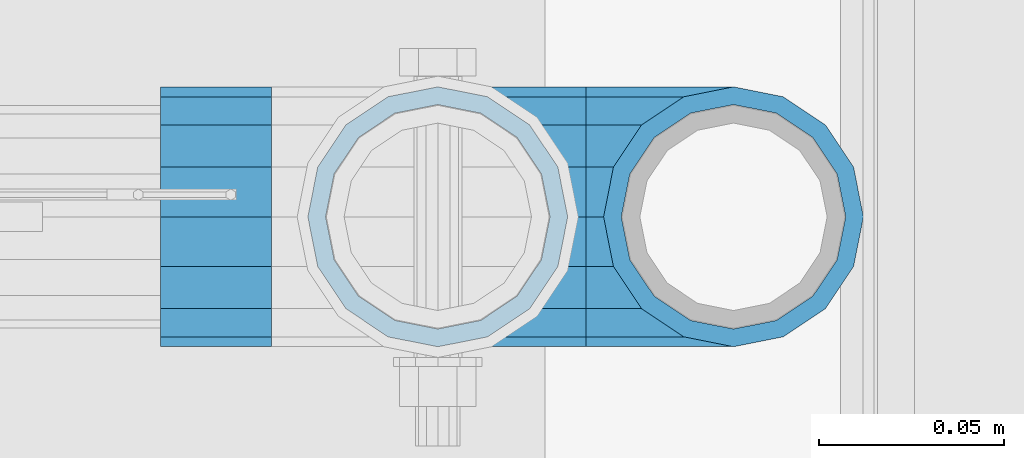
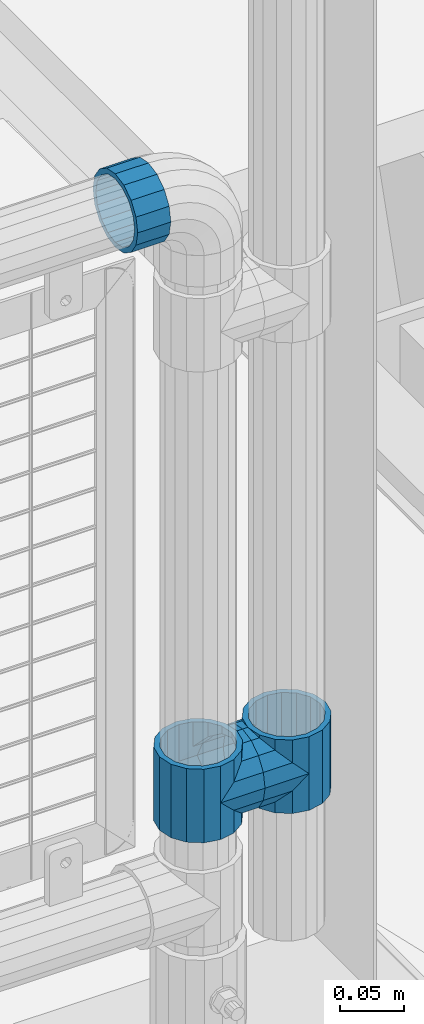
# One storey, part 130 of 193: 5 beams.
"""IFC2X3 building model written with IfcOpenShell, lengths in millimetres."""

from ifc_helpers import new_model, si_unit, frame, origin_with_axes, place, context, subcontext, project, spatial, faceted_brep, material, type_object, element, save


model = new_model("IFC2X3")

# Units and contexts
model_context = context("Model", 3, precision=1e-05, world=origin_with_axes())
body_context = subcontext(model_context, "Body", "Model", "MODEL_VIEW")
ifc_project = project(units=[si_unit("LENGTHUNIT", "METRE", prefix="MILLI"), si_unit("AREAUNIT", "SQUARE_METRE"), si_unit("VOLUMEUNIT", "CUBIC_METRE"), si_unit("MASSUNIT", "GRAM", prefix="KILO"), si_unit("TIMEUNIT", "SECOND"), si_unit("PLANEANGLEUNIT", "RADIAN"), si_unit("SOLIDANGLEUNIT", "STERADIAN"), si_unit("THERMODYNAMICTEMPERATUREUNIT", "DEGREE_CELSIUS"), si_unit("LUMINOUSINTENSITYUNIT", "LUMEN")], contexts=[model_context])

# Site, building, storey
site_placement = place(None, origin_with_axes())
site = spatial("IfcSite", under=ifc_project, at=site_placement, CompositionType="ELEMENT")
building_placement = place(site_placement, origin_with_axes())
building = spatial("IfcBuilding", under=site, at=building_placement, Name="Standard", CompositionType="ELEMENT")
storey_placement = place(building_placement, origin_with_axes())
storey = spatial("IfcBuildingStorey", under=building, at=storey_placement, Name="Undefined", CompositionType="ELEMENT", Elevation=0.0)

# Beams
ifc_material = material(Name="Misc_Undefined")
beam_type = type_object("IfcBeamType", PredefinedType="NOTDEFINED")
beam_1_placement = place(storey_placement, frame((-29019.0, 28664.5, 398.670000000003), z_axis=(0.0, -1.0, 0.0), x_axis=(1.0, 0.0, 0.0)))
element("IfcBeam", 1, at=beam_1_placement, inside=storey, type_object=beam_type, material=ifc_material, context=body_context, shape_type="Brep", body=[
    faceted_brep([(0.0, 0.0, -35.1500000000015), (13.4513226476338, -13.4513226476329, -32.4743655677703), (13.4513226476338, 13.4513226476329, -32.4743655677703), (32.4743655677703, 32.4743655677717, 13.4513226476338), (32.4743655677703, 26.8123795176754, 13.4513226476338), (27.1226768591041, 21.4606908090117, 21.46069080901), (24.8548033587067, 16.3810424080078, 24.8548033587067), (24.8548033587067, 24.8548033587072, 24.8548033587067), (0.0, 0.0, 35.1500000000015), (13.4513226476338, 13.4513226476329, 32.4743655677703), (13.4513226476338, -13.4513226476329, 32.4743655677703), (20.0882031229849, 11.6144421722805, 28.0397438117179), (16.6306603983685, 0.0, 30.3499999999985), (20.0882031229849, -11.6144421722805, 28.0397438117179), (24.8548033587067, -16.3810424080013, 24.8548033587067), (24.8548033587067, -24.8548033587072, 24.8548033587067), (27.1226768591041, -21.4606908090117, 21.46069080901), (32.4743655677703, -26.8123795176776, 13.4513226476338), (32.4743655677703, -32.4743655677717, 13.4513226476338), (32.8397438117208, -28.0397438117175, 11.614442172282), (35.1500000000015, -30.35, 0.0), (35.1500000000015, -35.15, 0.0), (32.4743655677703, -26.8123795176754, -13.4513226476338), (32.4743655677703, -32.4743655677717, -13.4513226476338), (32.8397438117172, -28.0397438117175, -11.614442172282), (24.8548033587067, -16.3810424080013, -24.8548033587067), (24.8548033587067, -24.8548033587072, -24.8548033587067), (27.1226768591114, -21.4606908090117, -21.46069080901), (20.0882031229849, -11.6144421722805, -28.0397438117179), (16.6306603983721, 0.0, -30.3499999999985), (20.0882031229849, 11.6144421722805, -28.0397438117179), (24.8548033587067, 16.3810424080013, -24.8548033587067), (24.8548033587067, 24.8548033587072, -24.8548033587067), (27.1226768591114, 21.4606908090117, -21.46069080901), (32.4743655677703, 26.8123795176776, -13.4513226476338), (32.4743655677703, 32.4743655677717, -13.4513226476338), (32.8397438117172, 28.0397438117175, -11.614442172282), (35.1500000000015, 30.35, 0.0), (35.1500000000015, 35.15, 0.0), (32.8397438117208, 28.0397438117175, 11.614442172282), (40.1500000000015, -35.15, 0.0), (40.1500000000015, -32.4743655677718, 13.4513226476338), (40.1500000000015, -24.8548033587072, 24.8548033587067), (40.1500000000015, -13.4513226476329, 32.4743655677703), (40.1500000000015, 0.0, 35.1500000000015), (40.1500000000015, 13.4513226476329, 32.4743655677703), (40.1500000000015, 24.8548033587072, 24.8548033587067), (40.1500000000015, 32.4743655677718, 13.4513226476338), (40.1500000000015, 35.15, 0.0), (40.1500000000015, -24.8548033587072, -24.8548033587067), (40.1500000000015, -32.4743655677718, -13.4513226476338), (40.1500000000015, -13.4513226476329, -32.4743655677703), (40.1500000000015, 0.0, -35.1500000000015), (40.1500000000015, 13.4513226476329, -32.4743655677703), (40.1500000000015, 24.8548033587072, -24.8548033587067), (40.1500000000015, 32.4743655677718, -13.4513226476338), (40.1500000000015, -21.4606908090117, 21.46069080901), (40.1500000000015, -11.6144421722805, 28.0397438117179), (40.1500000000015, 0.0, 30.3499999999985), (40.1500000000015, 11.6144421722805, 28.0397438117179), (40.1500000000015, 21.4606908090117, 21.46069080901), (40.1500000000015, 28.0397438117176, 11.614442172282), (40.1500000000015, 30.35, 0.0), (40.1500000000015, 28.0397438117176, -11.614442172282), (40.1500000000015, 21.4606908090117, -21.46069080901), (40.1500000000015, 11.6144421722805, -28.0397438117179), (40.1500000000015, 0.0, -30.3499999999985), (40.1500000000015, -11.6144421722805, -28.0397438117179), (40.1500000000015, -21.4606908090117, -21.46069080901), (40.1500000000015, -28.0397438117176, -11.614442172282), (40.1500000000015, -30.35, 0.0), (40.1500000000015, -28.0397438117176, 11.614442172282)], [[[0, 1, 2]], [[3, 4, 5, 6, 7]], [[8, 9, 10]], [[7, 6, 11, 12, 13, 14, 15, 10, 9]], [[16, 17, 18, 15, 14]], [[19, 20, 21, 18, 17]], [[22, 23, 21, 20, 24]], [[25, 26, 23, 22, 27]], [[2, 1, 26, 25, 28, 29, 30, 31, 32]], [[32, 31, 33, 34, 35]], [[35, 34, 36, 37, 38]], [[38, 37, 39, 4, 3]], [[40, 41, 18, 21]], [[41, 42, 15, 18]], [[42, 43, 10, 15]], [[43, 44, 8, 10]], [[44, 45, 9, 8]], [[45, 46, 7, 9]], [[46, 47, 3, 7]], [[47, 48, 38, 3]], [[49, 50, 23, 26]], [[51, 49, 26, 1]], [[52, 51, 1, 0]], [[53, 52, 0, 2]], [[54, 53, 2, 32]], [[55, 54, 32, 35]], [[48, 55, 35, 38]], [[50, 40, 21, 23]], [[49, 51, 52, 53, 54, 55, 48, 47, 46, 45, 44, 43, 42, 41, 40, 50], [56, 57, 58, 59, 60, 61, 62, 63, 64, 65, 66, 67, 68, 69, 70, 71]], [[63, 62, 37, 36]], [[33, 64, 63, 36, 34]], [[30, 65, 64, 33, 31]], [[66, 65, 30, 29]], [[67, 66, 29, 28]], [[68, 67, 28, 25, 27]], [[69, 68, 27, 22, 24]], [[70, 69, 24, 20]], [[71, 70, 20, 19]], [[16, 56, 71, 19, 17]], [[13, 57, 56, 16, 14]], [[58, 57, 13, 12]], [[59, 58, 12, 11]], [[60, 59, 11, 6, 5]], [[61, 60, 5, 4, 39]], [[62, 61, 39, 37]]]),
])
beam_2_placement = place(storey_placement, frame((-28939.0, 28664.5, 398.670000000003), z_axis=(0.0, 1.0, 0.0), x_axis=(-1.0, 0.0, 0.0)))
element("IfcBeam", 2, at=beam_2_placement, inside=storey, type_object=beam_type, material=ifc_material, context=body_context, shape_type="Brep", body=[
    faceted_brep([(0.0, 0.0, -35.1500000000015), (13.4513226476338, -13.4513226476329, -32.4743655677703), (13.4513226476338, 13.4513226476329, -32.4743655677703), (27.1226768591041, -21.4606908090117, 21.46069080901), (32.4743655677703, -26.8123795176776, 13.4513226476338), (32.4743655677703, -32.4743655677717, 13.4513226476338), (24.8548033587067, -24.8548033587072, 24.8548033587067), (24.8548033587067, -16.3810424080013, 24.8548033587067), (32.8397438117208, -28.0397438117175, 11.614442172282), (35.1500000000015, -30.35, 0.0), (35.1500000000015, -35.15, 0.0), (32.4743655677703, -26.8123795176754, -13.4513226476338), (32.4743655677703, -32.4743655677717, -13.4513226476338), (32.8397438117172, -28.0397438117175, -11.614442172282), (24.8548033587067, -16.3810424080013, -24.8548033587067), (24.8548033587067, -24.8548033587072, -24.8548033587067), (27.1226768591114, -21.4606908090117, -21.46069080901), (20.0882031229849, -11.6144421722805, -28.0397438117179), (16.6306603983721, 0.0, -30.3499999999985), (20.0882031229849, 11.6144421722805, -28.0397438117179), (24.8548033587067, 16.3810424080013, -24.8548033587067), (24.8548033587067, 24.8548033587072, -24.8548033587067), (27.1226768591114, 21.4606908090117, -21.46069080901), (32.4743655677703, 26.8123795176776, -13.4513226476338), (32.4743655677703, 32.4743655677717, -13.4513226476338), (32.8397438117172, 28.0397438117175, -11.614442172282), (35.1500000000015, 30.35, 0.0), (35.1500000000015, 35.15, 0.0), (32.8397438117208, 28.0397438117175, 11.614442172282), (32.4743655677703, 26.8123795176754, 13.4513226476338), (32.4743655677703, 32.4743655677717, 13.4513226476338), (27.1226768591041, 21.4606908090117, 21.46069080901), (24.8548033587067, 16.3810424080078, 24.8548033587067), (24.8548033587067, 24.8548033587072, 24.8548033587067), (0.0, 0.0, 35.1500000000015), (13.4513226476338, 13.4513226476329, 32.4743655677703), (13.4513226476338, -13.4513226476329, 32.4743655677703), (20.0882031229849, 11.6144421722805, 28.0397438117179), (16.6306603983685, 0.0, 30.3499999999985), (20.0882031229849, -11.6144421722805, 28.0397438117179), (40.1500000000015, -35.15, 0.0), (40.1500000000015, -32.4743655677718, 13.4513226476338), (40.1500000000015, -24.8548033587072, 24.8548033587067), (40.1500000000015, -13.4513226476329, 32.4743655677703), (40.1500000000015, 0.0, 35.1500000000015), (40.1500000000015, -24.8548033587072, -24.8548033587067), (40.1500000000015, -32.4743655677718, -13.4513226476338), (40.1500000000015, -13.4513226476329, -32.4743655677703), (40.1500000000015, 0.0, -35.1500000000015), (40.1500000000015, 13.4513226476329, -32.4743655677703), (40.1500000000015, 24.8548033587072, -24.8548033587067), (40.1500000000015, 32.4743655677718, -13.4513226476338), (40.1500000000015, 35.15, 0.0), (40.1500000000015, 32.4743655677718, 13.4513226476338), (40.1500000000015, 24.8548033587072, 24.8548033587067), (40.1500000000015, 13.4513226476329, 32.4743655677703), (40.1500000000015, -21.4606908090117, 21.46069080901), (40.1500000000015, -11.6144421722805, 28.0397438117179), (40.1500000000015, 0.0, 30.3499999999985), (40.1500000000015, 11.6144421722805, 28.0397438117179), (40.1500000000015, 21.4606908090117, 21.46069080901), (40.1500000000015, 28.0397438117176, 11.614442172282), (40.1500000000015, 30.35, 0.0), (40.1500000000015, 28.0397438117176, -11.614442172282), (40.1500000000015, 21.4606908090117, -21.46069080901), (40.1500000000015, 11.6144421722805, -28.0397438117179), (40.1500000000015, 0.0, -30.3499999999985), (40.1500000000015, -11.6144421722805, -28.0397438117179), (40.1500000000015, -21.4606908090117, -21.46069080901), (40.1500000000015, -28.0397438117176, -11.614442172282), (40.1500000000015, -30.35, 0.0), (40.1500000000015, -28.0397438117176, 11.614442172282)], [[[0, 1, 2]], [[3, 4, 5, 6, 7]], [[8, 9, 10, 5, 4]], [[11, 12, 10, 9, 13]], [[14, 15, 12, 11, 16]], [[2, 1, 15, 14, 17, 18, 19, 20, 21]], [[21, 20, 22, 23, 24]], [[24, 23, 25, 26, 27]], [[27, 26, 28, 29, 30]], [[30, 29, 31, 32, 33]], [[34, 35, 36]], [[33, 32, 37, 38, 39, 7, 6, 36, 35]], [[40, 41, 5, 10]], [[41, 42, 6, 5]], [[42, 43, 36, 6]], [[43, 44, 34, 36]], [[45, 46, 12, 15]], [[47, 45, 15, 1]], [[48, 47, 1, 0]], [[49, 48, 0, 2]], [[50, 49, 2, 21]], [[51, 50, 21, 24]], [[52, 51, 24, 27]], [[53, 52, 27, 30]], [[54, 53, 30, 33]], [[55, 54, 33, 35]], [[44, 55, 35, 34]], [[46, 40, 10, 12]], [[45, 47, 48, 49, 50, 51, 52, 53, 54, 55, 44, 43, 42, 41, 40, 46], [56, 57, 58, 59, 60, 61, 62, 63, 64, 65, 66, 67, 68, 69, 70, 71]], [[59, 58, 38, 37]], [[60, 59, 37, 32, 31]], [[61, 60, 31, 29, 28]], [[62, 61, 28, 26]], [[63, 62, 26, 25]], [[22, 64, 63, 25, 23]], [[19, 65, 64, 22, 20]], [[66, 65, 19, 18]], [[67, 66, 18, 17]], [[68, 67, 17, 14, 16]], [[69, 68, 16, 11, 13]], [[70, 69, 13, 9]], [[71, 70, 9, 8]], [[3, 56, 71, 8, 4]], [[39, 57, 56, 3, 7]], [[58, 57, 39, 38]]]),
])
beam_3_placement = place(storey_placement, frame((-29019.0, 28664.5, 433.820000000003), z_axis=(-1.0, 0.0, 0.0), x_axis=(0.0, 0.0, -1.0)))
element("IfcBeam", 3, at=beam_3_placement, inside=storey, type_object=beam_type, material=ifc_material, context=body_context, shape_type="Brep", body=[
    faceted_brep([(13.6893091909879, -21.46069080901, -21.46069080901), (13.6893091909879, -21.46069080901, -27.1226768591114), (8.33762048232484, -13.4513226476338, -32.4743655677703), (7.11025618828211, -11.614442172282, -32.8397438117172), (7.11025618828211, -11.614442172282, -28.0397438117179), (23.5355578277191, -28.0397438117179, -11.614442172282), (23.5355578277191, -28.0397438117179, -20.0882031229812), (18.7689575919921, -24.8548033587067, -24.8548033587067), (35.1500000000015, -30.35, 0.0), (35.1499999999996, -30.3499999999985, -16.6306603983721), (46.7644421722801, -28.0397438117179, -11.614442172282), (46.7644421722801, -28.0397438117179, -20.0882031229812), (56.6106908090114, -21.46069080901, -21.46069080901), (56.6106908090114, -21.46069080901, -27.1226768591114), (51.5310424080006, -24.8548033587067, -24.8548033587067), (63.1897438117172, -11.614442172282, -28.0397438117179), (63.1897438117172, -11.614442172282, -32.8397438117172), (61.9623795176767, -13.4513226476338, -32.4743655677703), (65.4999999999997, 0.0, -30.3499999999985), (65.4999999999997, 0.0, -35.1500000000015), (63.1897438117172, 11.614442172282, -28.0397438117179), (63.1897438117172, 11.614442172282, -32.8397438117245), (56.6106908090114, 21.46069080901, -21.46069080901), (56.6106908090114, 21.46069080901, -27.1226768591041), (61.9623795176744, 13.4513226476338, -32.4743655677703), (46.7644421722801, 28.0397438117179, -11.614442172282), (46.7644421722801, 28.0397438117179, -20.0882031229849), (51.5310424080006, 24.8548033587067, -24.8548033587067), (35.1500000000015, 30.35, 0.0), (35.1499999999996, 30.3499999999985, -16.6306603983685), (23.5355578277192, 28.0397438117179, -11.614442172282), (23.5355578277192, 28.0397438117179, -20.0882031229849), (13.6893091909879, 21.46069080901, -21.46069080901), (13.6893091909879, 21.46069080901, -27.1226768591041), (18.7689575919987, 24.8548033587067, -24.8548033587067), (7.11025618828211, 11.614442172282, -28.0397438117179), (7.11025618828211, 11.614442172282, -32.8397438117245), (8.33762048232262, 13.4513226476338, -32.4743655677703), (4.79999999999961, 0.0, -30.3499999999985), (4.79999999999961, 0.0, -35.1500000000015), (0.0, 21.46069080901, 21.46069080901), (0.0, 28.0397438117179, 11.614442172282), (70.2999999999993, 28.0397438117179, 11.614442172282), (70.2999999999993, 21.46069080901, 21.46069080901), (0.0, 11.614442172282, 28.0397438117179), (70.2999999999993, 11.614442172282, 28.0397438117179), (0.0, 0.0, 30.3499999999985), (70.2999999999993, 0.0, 30.3499999999985), (0.0, -11.614442172282, 28.0397438117179), (70.2999999999993, -11.614442172282, 28.0397438117179), (0.0, -21.46069080901, 21.46069080901), (70.2999999999993, -21.46069080901, 21.46069080901), (0.0, -28.0397438117179, 11.614442172282), (70.2999999999993, -28.0397438117179, 11.614442172282), (0.0, -24.8548033587067, -24.8548033587067), (0.0, -13.4513226476338, -32.4743655677703), (0.0, 0.0, -35.1500000000015), (0.0, -32.4743655677703, 13.4513226476338), (0.0, -35.1500000000015, 0.0), (70.2999999999993, -35.1500000000015, 0.0), (70.2999999999993, -32.4743655677703, 13.4513226476338), (0.0, -24.8548033587067, 24.8548033587067), (70.2999999999993, -24.8548033587067, 24.8548033587067), (0.0, -13.4513226476338, 32.4743655677703), (70.2999999999993, -13.4513226476338, 32.4743655677703), (0.0, 0.0, 35.1500000000015), (70.2999999999993, 0.0, 35.1500000000015), (0.0, 13.4513226476338, 32.4743655677703), (70.2999999999993, 13.4513226476338, 32.4743655677703), (0.0, 24.8548033587067, 24.8548033587067), (70.2999999999993, 24.8548033587067, 24.8548033587067), (0.0, 32.4743655677703, 13.4513226476338), (70.2999999999993, 32.4743655677703, 13.4513226476338), (0.0, 35.1500000000015, 0.0), (70.2999999999993, 35.1500000000015, 0.0), (0.0, 32.4743655677703, -13.4513226476338), (70.2999999999993, 32.4743655677703, -13.4513226476338), (70.2999999999993, -13.4513226476338, -32.4743655677703), (70.2999999999993, -24.8548033587067, -24.8548033587067), (70.2999999999993, 0.0, -35.1500000000015), (70.2999999999993, 13.4513226476338, -32.4743655677703), (70.2999999999993, 24.8548033587067, -24.8548033587067), (0.0, 24.8548033587067, -24.8548033587067), (0.0, 13.4513226476338, -32.4743655677703), (70.2999999999993, -32.4743655677703, -13.4513226476338), (0.0, -32.4743655677703, -13.4513226476338), (0.0, -28.0397438117179, -11.614442172282), (0.0, -21.46069080901, -21.46069080901), (0.0, -11.614442172282, -28.0397438117179), (0.0, 0.0, -30.3499999999985), (0.0, 11.614442172282, -28.0397438117179), (0.0, 21.46069080901, -21.46069080901), (0.0, 28.0397438117179, -11.614442172282), (0.0, 30.3499999999985, 0.0), (0.0, -30.3499999999985, 0.0), (70.2999999999993, 30.3499999999985, 0.0), (70.2999999999993, 28.0397438117179, -11.614442172282), (70.2999999999993, 21.46069080901, -21.46069080901), (70.2999999999993, 11.614442172282, -28.0397438117179), (70.2999999999993, 0.0, -30.3499999999985), (70.2999999999993, -11.614442172282, -28.0397438117179), (70.2999999999993, -21.46069080901, -21.46069080901), (70.2999999999993, -28.0397438117179, -11.614442172282), (70.2999999999993, -30.3499999999985, 0.0)], [[[0, 1, 2, 3, 4]], [[5, 6, 7, 1, 0]], [[8, 9, 6, 5]], [[10, 11, 9, 8]], [[12, 13, 14, 11, 10]], [[15, 16, 17, 13, 12]], [[18, 19, 16, 15]], [[20, 21, 19, 18]], [[22, 23, 24, 21, 20]], [[25, 26, 27, 23, 22]], [[28, 29, 26, 25]], [[30, 31, 29, 28]], [[32, 33, 34, 31, 30]], [[35, 36, 37, 33, 32]], [[38, 39, 36, 35]], [[4, 3, 39, 38]], [[40, 41, 42, 43]], [[44, 40, 43, 45]], [[46, 44, 45, 47]], [[48, 46, 47, 49]], [[50, 48, 49, 51]], [[52, 50, 51, 53]], [[54, 55, 2, 1, 7]], [[55, 56, 39, 3, 2]], [[57, 58, 59, 60]], [[61, 57, 60, 62]], [[63, 61, 62, 64]], [[65, 63, 64, 66]], [[67, 65, 66, 68]], [[69, 67, 68, 70]], [[71, 69, 70, 72]], [[73, 71, 72, 74]], [[75, 73, 74, 76]], [[17, 77, 78, 14, 13]], [[19, 79, 77, 17, 16]], [[80, 79, 19, 21, 24]], [[81, 80, 24, 23, 27]], [[34, 82, 75, 76, 81, 27, 26, 29, 31]], [[37, 83, 82, 34, 33]], [[39, 56, 83, 37, 36]], [[14, 78, 84, 85, 54, 7, 6, 9, 11]], [[58, 85, 84, 59]], [[57, 61, 63, 65, 67, 69, 71, 73, 75, 82, 83, 56, 55, 54, 85, 58], [86, 87, 88, 89, 90, 91, 92, 93, 41, 40, 44, 46, 48, 50, 52, 94]], [[90, 89, 38, 35]], [[91, 90, 35, 32]], [[92, 91, 32, 30]], [[93, 92, 30, 28]], [[41, 93, 28, 95, 42]], [[96, 95, 28, 25]], [[97, 96, 25, 22]], [[98, 97, 22, 20]], [[99, 98, 20, 18]], [[100, 99, 18, 15]], [[101, 100, 15, 12]], [[102, 101, 12, 10]], [[103, 102, 10, 8]], [[78, 77, 79, 80, 81, 76, 74, 72, 70, 68, 66, 64, 62, 60, 59, 84], [51, 49, 47, 45, 43, 42, 95, 96, 97, 98, 99, 100, 101, 102, 103, 53]], [[8, 94, 52, 53, 103]], [[86, 94, 8, 5]], [[87, 86, 5, 0]], [[88, 87, 0, 4]], [[89, 88, 4, 38]]]),
])
beam_4_placement = place(storey_placement, frame((-28939.0, 28664.5, 433.820000000003), z_axis=(1.0, 0.0, 0.0), x_axis=(0.0, 0.0, -1.0)))
element("IfcBeam", 4, at=beam_4_placement, inside=storey, type_object=beam_type, material=ifc_material, context=body_context, shape_type="Brep", body=[
    faceted_brep([(46.7644421722801, 28.0397438117179, -11.614442172282), (46.7644421722801, 28.0397438117179, -20.0882031229849), (51.5310424080006, 24.8548033587067, -24.8548033587067), (56.6106908090114, 21.46069080901, -27.1226768591041), (56.6106908090114, 21.46069080901, -21.46069080901), (61.9623795176744, 13.4513226476338, -32.4743655677703), (63.1897438117172, 11.614442172282, -32.8397438117245), (63.1897438117172, 11.614442172282, -28.0397438117179), (65.4999999999997, 0.0, -35.1500000000015), (65.4999999999997, 0.0, -30.3499999999985), (63.1897438117172, -11.614442172282, -32.8397438117172), (63.1897438117172, -11.614442172282, -28.0397438117179), (61.9623795176767, -13.4513226476338, -32.4743655677703), (56.6106908090114, -21.46069080901, -27.1226768591114), (56.6106908090114, -21.46069080901, -21.46069080901), (51.5310424080006, -24.8548033587067, -24.8548033587067), (46.7644421722801, -28.0397438117179, -20.0882031229812), (46.7644421722801, -28.0397438117179, -11.614442172282), (35.1499999999996, -30.3499999999985, -16.6306603983721), (35.1500000000015, -30.35, 0.0), (23.5355578277191, -28.0397438117179, -20.0882031229812), (23.5355578277191, -28.0397438117179, -11.614442172282), (18.7689575919921, -24.8548033587067, -24.8548033587067), (13.6893091909879, -21.46069080901, -27.1226768591114), (13.6893091909879, -21.46069080901, -21.46069080901), (8.33762048232484, -13.4513226476338, -32.4743655677703), (7.11025618828211, -11.614442172282, -32.8397438117172), (7.11025618828211, -11.614442172282, -28.0397438117179), (4.79999999999961, 0.0, -35.1500000000015), (4.79999999999961, 0.0, -30.3499999999985), (7.11025618828211, 11.614442172282, -32.8397438117245), (7.11025618828211, 11.614442172282, -28.0397438117179), (8.33762048232262, 13.4513226476338, -32.4743655677703), (13.6893091909879, 21.46069080901, -27.1226768591041), (13.6893091909879, 21.46069080901, -21.46069080901), (18.7689575919987, 24.8548033587067, -24.8548033587067), (23.5355578277192, 28.0397438117179, -20.0882031229849), (23.5355578277192, 28.0397438117179, -11.614442172282), (35.1499999999996, 30.3499999999985, -16.6306603983685), (35.1500000000015, 30.35, 0.0), (0.0, 32.4743655677703, -13.4513226476338), (0.0, 35.1500000000015, 0.0), (70.2999999999993, 35.1500000000015, 0.0), (70.2999999999993, 32.4743655677703, -13.4513226476338), (0.0, 32.4743655677703, 13.4513226476338), (70.2999999999993, 32.4743655677703, 13.4513226476338), (0.0, 24.8548033587067, 24.8548033587067), (70.2999999999993, 24.8548033587067, 24.8548033587067), (0.0, 13.4513226476338, 32.4743655677703), (70.2999999999993, 13.4513226476338, 32.4743655677703), (0.0, 0.0, 35.1500000000015), (70.2999999999993, 0.0, 35.1500000000015), (0.0, -13.4513226476338, 32.4743655677703), (70.2999999999993, -13.4513226476338, 32.4743655677703), (0.0, -24.8548033587067, 24.8548033587067), (70.2999999999993, -24.8548033587067, 24.8548033587067), (0.0, -32.4743655677703, 13.4513226476338), (70.2999999999993, -32.4743655677703, 13.4513226476338), (0.0, -35.1500000000015, 0.0), (70.2999999999993, -35.1500000000015, 0.0), (70.2999999999993, -30.3499999999985, 0.0), (70.2999999999993, -28.0397438117179, -11.614442172282), (70.2999999999993, -21.46069080901, -21.46069080901), (70.2999999999993, -11.614442172282, -28.0397438117179), (70.2999999999993, 0.0, -30.3499999999985), (70.2999999999993, 11.614442172282, -28.0397438117179), (70.2999999999993, 21.46069080901, -21.46069080901), (70.2999999999993, 28.0397438117179, -11.614442172282), (0.0, -28.0397438117179, -11.614442172282), (0.0, -30.3499999999985, 0.0), (0.0, -21.46069080901, -21.46069080901), (0.0, -11.614442172282, -28.0397438117179), (0.0, 0.0, -30.3499999999985), (0.0, 11.614442172282, -28.0397438117179), (0.0, 21.46069080901, -21.46069080901), (0.0, 28.0397438117179, -11.614442172282), (0.0, 30.3499999999985, 0.0), (70.2999999999993, 30.3499999999985, 0.0), (0.0, 28.0397438117179, 11.614442172282), (70.2999999999993, 28.0397438117179, 11.614442172282), (0.0, 21.46069080901, 21.46069080901), (70.2999999999993, 21.46069080901, 21.46069080901), (0.0, 11.614442172282, 28.0397438117179), (70.2999999999993, 11.614442172282, 28.0397438117179), (0.0, 0.0, 30.3499999999985), (70.2999999999993, 0.0, 30.3499999999985), (0.0, -11.614442172282, 28.0397438117179), (70.2999999999993, -11.614442172282, 28.0397438117179), (0.0, -21.46069080901, 21.46069080901), (70.2999999999993, -21.46069080901, 21.46069080901), (0.0, -28.0397438117179, 11.614442172282), (70.2999999999993, -28.0397438117179, 11.614442172282), (70.2999999999993, -24.8548033587067, -24.8548033587067), (70.2999999999993, -13.4513226476338, -32.4743655677703), (70.2999999999993, 0.0, -35.1500000000015), (70.2999999999993, 13.4513226476338, -32.4743655677703), (70.2999999999993, 24.8548033587067, -24.8548033587067), (70.2999999999993, -32.4743655677703, -13.4513226476338), (0.0, -32.4743655677703, -13.4513226476338), (0.0, 24.8548033587067, -24.8548033587067), (0.0, 13.4513226476338, -32.4743655677703), (0.0, 0.0, -35.1500000000015), (0.0, -13.4513226476338, -32.4743655677703), (0.0, -24.8548033587067, -24.8548033587067)], [[[0, 1, 2, 3, 4]], [[4, 3, 5, 6, 7]], [[7, 6, 8, 9]], [[9, 8, 10, 11]], [[11, 10, 12, 13, 14]], [[14, 13, 15, 16, 17]], [[17, 16, 18, 19]], [[19, 18, 20, 21]], [[21, 20, 22, 23, 24]], [[24, 23, 25, 26, 27]], [[27, 26, 28, 29]], [[29, 28, 30, 31]], [[31, 30, 32, 33, 34]], [[34, 33, 35, 36, 37]], [[37, 36, 38, 39]], [[39, 38, 1, 0]], [[40, 41, 42, 43]], [[41, 44, 45, 42]], [[44, 46, 47, 45]], [[46, 48, 49, 47]], [[48, 50, 51, 49]], [[50, 52, 53, 51]], [[52, 54, 55, 53]], [[54, 56, 57, 55]], [[56, 58, 59, 57]], [[60, 61, 17, 19]], [[61, 62, 14, 17]], [[62, 63, 11, 14]], [[63, 64, 9, 11]], [[64, 65, 7, 9]], [[65, 66, 4, 7]], [[66, 67, 0, 4]], [[68, 69, 19, 21]], [[70, 68, 21, 24]], [[71, 70, 24, 27]], [[72, 71, 27, 29]], [[73, 72, 29, 31]], [[74, 73, 31, 34]], [[75, 74, 34, 37]], [[76, 75, 37, 39]], [[67, 77, 39, 0]], [[78, 76, 39, 77, 79]], [[80, 78, 79, 81]], [[82, 80, 81, 83]], [[84, 82, 83, 85]], [[86, 84, 85, 87]], [[88, 86, 87, 89]], [[90, 88, 89, 91]], [[19, 69, 90, 91, 60]], [[92, 93, 94, 95, 96, 43, 42, 45, 47, 49, 51, 53, 55, 57, 59, 97], [89, 87, 85, 83, 81, 79, 77, 67, 66, 65, 64, 63, 62, 61, 60, 91]], [[58, 98, 97, 59]], [[56, 54, 52, 50, 48, 46, 44, 41, 40, 99, 100, 101, 102, 103, 98, 58], [68, 70, 71, 72, 73, 74, 75, 76, 78, 80, 82, 84, 86, 88, 90, 69]], [[32, 100, 99, 35, 33]], [[28, 101, 100, 32, 30]], [[102, 101, 28, 26, 25]], [[103, 102, 25, 23, 22]], [[15, 92, 97, 98, 103, 22, 20, 18, 16]], [[12, 93, 92, 15, 13]], [[8, 94, 93, 12, 10]], [[95, 94, 8, 6, 5]], [[96, 95, 5, 3, 2]], [[35, 99, 40, 43, 96, 2, 1, 38, 36]]]),
])
beam_5_placement = place(storey_placement, frame((-29064.0, 28664.5, 969.85), z_axis=(0.0, 0.0, 1.0), x_axis=(-1.0, 0.0, 0.0)))
element("IfcBeam", 5, at=beam_5_placement, inside=storey, type_object=beam_type, material=ifc_material, context=body_context, shape_type="Brep", body=[
    faceted_brep([(0.0, -30.3499999999985, 0.0), (0.0, -28.0397438117179, 11.614442172282), (30.0, -28.0397438117179, 11.6144421722805), (30.0, -30.3499999999985, 0.0), (0.0, -21.46069080901, 21.46069080901), (30.0, -21.46069080901, 21.4606908090117), (0.0, -11.614442172282, 28.0397438117179), (30.0, -11.614442172282, 28.0397438117176), (0.0, 0.0, 30.3499999999985), (30.0, 0.0, 30.35), (0.0, 11.614442172282, 28.0397438117179), (30.0, 11.614442172282, 28.0397438117176), (0.0, 21.46069080901, 21.46069080901), (30.0, 21.46069080901, 21.4606908090117), (0.0, 28.0397438117179, 11.614442172282), (30.0, 28.0397438117179, 11.6144421722805), (0.0, 30.3499999999985, 0.0), (30.0, 30.3499999999985, 0.0), (0.0, 28.0397438117179, -11.614442172282), (30.0, 28.0397438117179, -11.6144421722805), (0.0, 21.46069080901, -21.46069080901), (30.0, 21.46069080901, -21.4606908090117), (0.0, 11.614442172282, -28.0397438117179), (30.0, 11.614442172282, -28.0397438117176), (0.0, 0.0, -30.3499999999985), (30.0, 0.0, -30.35), (0.0, -11.614442172282, -28.0397438117179), (30.0, -11.614442172282, -28.0397438117176), (0.0, -21.46069080901, -21.46069080901), (30.0, -21.46069080901, -21.4606908090117), (0.0, -28.0397438117179, -11.614442172282), (30.0, -28.0397438117179, -11.6144421722805), (0.0, -35.1500000000015, 0.0), (0.0, -32.4743655677703, -13.4513226476338), (30.0, -32.4743655677703, -13.4513226476329), (30.0, -35.1500000000015, 0.0), (0.0, -24.8548033587067, -24.8548033587067), (30.0, -24.8548033587067, -24.8548033587072), (0.0, -13.4513226476338, -32.4743655677703), (30.0, -13.4513226476338, -32.4743655677718), (0.0, 0.0, -35.1500000000015), (30.0, 0.0, -35.15), (0.0, 13.4513226476338, -32.4743655677703), (30.0, 13.4513226476338, -32.4743655677718), (0.0, 24.8548033587067, -24.8548033587067), (30.0, 24.8548033587067, -24.8548033587072), (0.0, 32.4743655677703, -13.4513226476338), (30.0, 32.4743655677703, -13.4513226476329), (0.0, 35.1500000000015, 0.0), (30.0, 35.1500000000015, 0.0), (0.0, 32.4743655677703, 13.4513226476338), (30.0, 32.4743655677703, 13.4513226476329), (0.0, 24.8548033587067, 24.8548033587067), (30.0, 24.8548033587067, 24.8548033587072), (0.0, 13.4513226476338, 32.4743655677703), (30.0, 13.4513226476338, 32.4743655677718), (0.0, 0.0, 35.1500000000015), (30.0, 0.0, 35.15), (0.0, -13.4513226476338, 32.4743655677703), (30.0, -13.4513226476338, 32.4743655677718), (0.0, -24.8548033587067, 24.8548033587067), (30.0, -24.8548033587067, 24.8548033587072), (0.0, -32.4743655677703, 13.4513226476338), (30.0, -32.4743655677703, 13.4513226476329)], [[[0, 1, 2, 3]], [[1, 4, 5, 2]], [[4, 6, 7, 5]], [[6, 8, 9, 7]], [[8, 10, 11, 9]], [[10, 12, 13, 11]], [[12, 14, 15, 13]], [[14, 16, 17, 15]], [[16, 18, 19, 17]], [[18, 20, 21, 19]], [[20, 22, 23, 21]], [[22, 24, 25, 23]], [[24, 26, 27, 25]], [[26, 28, 29, 27]], [[28, 30, 31, 29]], [[30, 0, 3, 31]], [[32, 33, 34, 35]], [[33, 36, 37, 34]], [[36, 38, 39, 37]], [[38, 40, 41, 39]], [[40, 42, 43, 41]], [[42, 44, 45, 43]], [[44, 46, 47, 45]], [[46, 48, 49, 47]], [[48, 50, 51, 49]], [[50, 52, 53, 51]], [[52, 54, 55, 53]], [[54, 56, 57, 55]], [[56, 58, 59, 57]], [[58, 60, 61, 59]], [[60, 62, 63, 61]], [[62, 32, 35, 63]], [[37, 39, 41, 43, 45, 47, 49, 51, 53, 55, 57, 59, 61, 63, 35, 34], [5, 7, 9, 11, 13, 15, 17, 19, 21, 23, 25, 27, 29, 31, 3, 2]], [[62, 60, 58, 56, 54, 52, 50, 48, 46, 44, 42, 40, 38, 36, 33, 32], [30, 28, 26, 24, 22, 20, 18, 16, 14, 12, 10, 8, 6, 4, 1, 0]]]),
])

save(model, "model.ifc")
